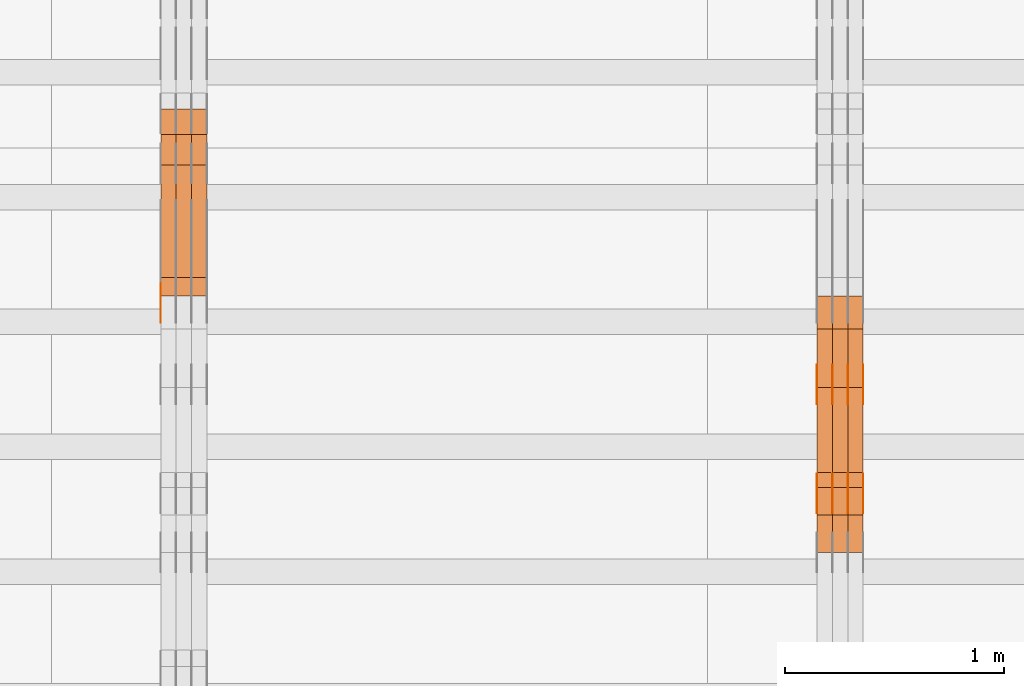
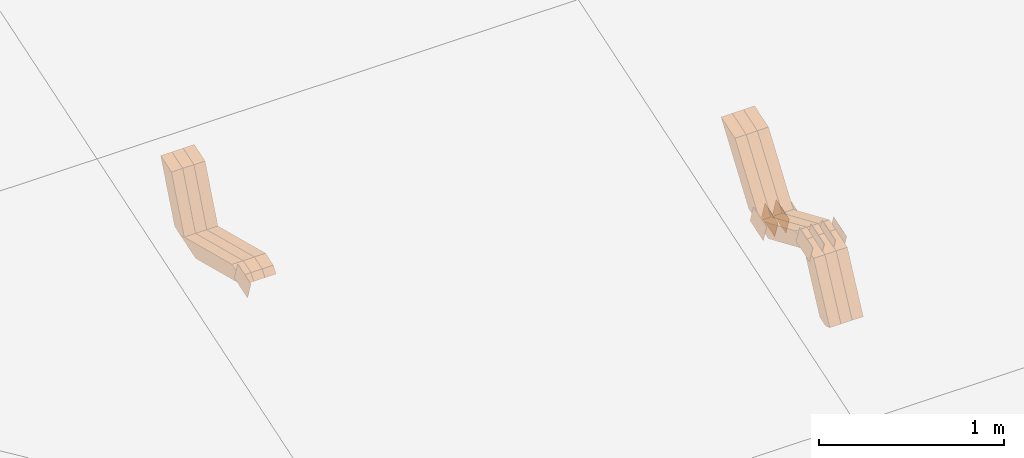
# One storey, part 133 of 385: 28 proxies.
"""IFC2X3 building model written with IfcOpenShell, lengths in millimetres."""

from ifc_helpers import new_model, entity, si_unit, converted_unit, derived_unit, direction, frame, origin, place, context, subcontext, project, spatial, polyline, outline, extrude, source, transform, mapped, material, type_object, type_shapes, element, save


model = new_model("IFC2X3")

# Units and contexts
model_context = context("Model", 3, precision=0.01, world=origin(), true_north=direction((6.12303176911189e-17, 1.0)))
body_context = subcontext(model_context, "Body", "Model", "MODEL_VIEW")
ifc_project = project(units=[si_unit("LENGTHUNIT", "METRE", prefix="MILLI"), si_unit("AREAUNIT", "SQUARE_METRE"), si_unit("VOLUMEUNIT", "CUBIC_METRE"), converted_unit("PLANEANGLEUNIT", "DEGREE", entity("IfcRatioMeasure", 0.0174532925199433), si_unit("PLANEANGLEUNIT", "RADIAN"), dimensions=[0, 0, 0, 0, 0, 0, 0]), si_unit("MASSUNIT", "GRAM", prefix="KILO"), derived_unit("MASSDENSITYUNIT", [(si_unit("MASSUNIT", "GRAM", prefix="KILO"), 1), (si_unit("LENGTHUNIT", "METRE"), -3)]), si_unit("TIMEUNIT", "SECOND"), si_unit("FREQUENCYUNIT", "HERTZ"), si_unit("THERMODYNAMICTEMPERATUREUNIT", "DEGREE_CELSIUS"), derived_unit("THERMALTRANSMITTANCEUNIT", [(si_unit("MASSUNIT", "GRAM", prefix="KILO"), 1), (si_unit("THERMODYNAMICTEMPERATUREUNIT", "KELVIN"), -1), (si_unit("TIMEUNIT", "SECOND"), -3)]), derived_unit("VOLUMETRICFLOWRATEUNIT", [(si_unit("LENGTHUNIT", "METRE"), 3), (si_unit("TIMEUNIT", "SECOND"), -1)]), si_unit("ELECTRICCURRENTUNIT", "AMPERE"), si_unit("ELECTRICVOLTAGEUNIT", "VOLT"), si_unit("POWERUNIT", "WATT"), si_unit("FORCEUNIT", "NEWTON", prefix="KILO"), si_unit("ILLUMINANCEUNIT", "LUX"), si_unit("LUMINOUSFLUXUNIT", "LUMEN"), si_unit("LUMINOUSINTENSITYUNIT", "CANDELA"), derived_unit("USERDEFINED", [(si_unit("MASSUNIT", "GRAM", prefix="KILO"), -1), (si_unit("LENGTHUNIT", "METRE"), -2), (si_unit("TIMEUNIT", "SECOND"), 3), (si_unit("LUMINOUSFLUXUNIT", "LUMEN"), 1)]), derived_unit("LINEARVELOCITYUNIT", [(si_unit("LENGTHUNIT", "METRE"), 1), (si_unit("TIMEUNIT", "SECOND"), -1)]), si_unit("PRESSUREUNIT", "PASCAL"), derived_unit("USERDEFINED", [(si_unit("LENGTHUNIT", "METRE"), -2), (si_unit("MASSUNIT", "GRAM", prefix="KILO"), 1), (si_unit("TIMEUNIT", "SECOND"), -2)])], contexts=[model_context])

# Site, building, storey
site_placement = place(None, origin())
site = spatial("IfcSite", under=ifc_project, at=site_placement, CompositionType="ELEMENT")
building_placement = place(site_placement, origin())
building = spatial("IfcBuilding", under=site, at=building_placement, CompositionType="ELEMENT")
storey_placement = place(building_placement, origin())
storey = spatial("IfcBuildingStorey", under=building, at=storey_placement, Name="Default", CompositionType="ELEMENT", Elevation=0.0)

# Proxies
ifc_material_1 = material(Name="IfcSurfaceStyle #345500")
building_element_proxy_type_1 = type_object("IfcBuildingElementProxyType", PredefinedType="NOTDEFINED", material=ifc_material_1)
shared_shape_1 = source(origin(), body_context, "Body", "SweptSolid", [
    extrude(outline(polyline([(-74.9998565677169, -60.0000596852269), (74.9998794200137, -60.0000596852269), (74.9998565677151, 60.0000596852269), (-74.9998794200119, 60.0000596852269), (-74.9998565677169, -60.0000596852269)])), frame((74.9998794200137, 60.0000596852269, 0.0), z_axis=(0.0, 0.0, 1.0), x_axis=(-1.0, 0.0, 0.0)), (0.0, 0.0, 1.0), 1.3),
])
type_shapes(building_element_proxy_type_1, [shared_shape_1])
proxy_1_placement = place(building_placement, frame((27386.3, 7527.6269081625, 1621.97418552253), z_axis=(-1.0, 0.0, 0.0), x_axis=(0.0, 0.951056516295124, 0.309016994375039)))
element("IfcBuildingElementProxy", 1, at=proxy_1_placement, inside=storey, type_object=building_element_proxy_type_1, material=ifc_material_1, context=body_context, shape_type="MappedRepresentation", body=[
    mapped(shared_shape_1, transform((0.0, 0.0, 0.0), scale=1.0)),
])
ifc_material_2 = material(Name="IfcSurfaceStyle #345443")
building_element_proxy_type_2 = type_object("IfcBuildingElementProxyType", PredefinedType="NOTDEFINED", material=ifc_material_2)
shared_shape_2 = source(origin(), body_context, "Body", "SweptSolid", [
    extrude(outline(polyline([(-74.9998565677169, -60.0000596852269), (74.9998794200137, -60.0000596852269), (74.9998565677151, 60.0000596852269), (-74.9998794200119, 60.0000596852269), (-74.9998565677169, -60.0000596852269)])), frame((74.9998794200137, 60.0000596852269, 0.0), z_axis=(0.0, 0.0, 1.0), x_axis=(-1.0, 0.0, 0.0)), (0.0, 0.0, 1.0), 1.3),
])
type_shapes(building_element_proxy_type_2, [shared_shape_2])
proxy_2_placement = place(building_placement, frame((27315.0, 7527.6269081625, 1621.97418552253), z_axis=(-1.0, 0.0, 0.0), x_axis=(0.0, 0.951056516295124, 0.309016994375039)))
element("IfcBuildingElementProxy", 2, at=proxy_2_placement, inside=storey, type_object=building_element_proxy_type_2, material=ifc_material_2, context=body_context, shape_type="MappedRepresentation", body=[
    mapped(shared_shape_2, transform((0.0, 0.0, 0.0), scale=1.0)),
])
ifc_material_3 = material(Name="IfcSurfaceStyle #345386")
building_element_proxy_type_3 = type_object("IfcBuildingElementProxyType", PredefinedType="NOTDEFINED", material=ifc_material_3)
shared_shape_3 = source(origin(), body_context, "Body", "SweptSolid", [
    extrude(outline(polyline([(-74.9998565677169, -60.0000596852269), (74.9998794200137, -60.0000596852269), (74.9998565677151, 60.0000596852269), (-74.9998794200119, 60.0000596852269), (-74.9998565677169, -60.0000596852269)])), frame((74.9998794200137, 60.0000596852269, 0.0), z_axis=(0.0, 0.0, 1.0), x_axis=(-1.0, 0.0, 0.0)), (0.0, 0.0, 1.0), 1.3),
])
type_shapes(building_element_proxy_type_3, [shared_shape_3])
proxy_3_placement = place(building_placement, frame((27316.3, 7527.6269081625, 1621.97418552253), z_axis=(-1.0, 0.0, 0.0), x_axis=(0.0, 0.951056516295124, 0.309016994375039)))
element("IfcBuildingElementProxy", 3, at=proxy_3_placement, inside=storey, type_object=building_element_proxy_type_3, material=ifc_material_3, context=body_context, shape_type="MappedRepresentation", body=[
    mapped(shared_shape_3, transform((0.0, 0.0, 0.0), scale=1.0)),
])
ifc_material_4 = material(Name="IfcSurfaceStyle #345329")
building_element_proxy_type_4 = type_object("IfcBuildingElementProxyType", PredefinedType="NOTDEFINED", material=ifc_material_4)
shared_shape_4 = source(origin(), body_context, "Body", "SweptSolid", [
    extrude(outline(polyline([(-74.9998565677169, -60.0000596852269), (74.9998794200137, -60.0000596852269), (74.9998565677151, 60.0000596852269), (-74.9998794200119, 60.0000596852269), (-74.9998565677169, -60.0000596852269)])), frame((74.9998794200137, 60.0000596852269, 0.0), z_axis=(0.0, 0.0, 1.0), x_axis=(-1.0, 0.0, 0.0)), (0.0, 0.0, 1.0), 1.29999999999999),
])
type_shapes(building_element_proxy_type_4, [shared_shape_4])
proxy_4_placement = place(building_placement, frame((27245.0, 7527.6269081625, 1621.97418552253), z_axis=(-1.0, 0.0, 0.0), x_axis=(0.0, 0.951056516295124, 0.309016994375039)))
element("IfcBuildingElementProxy", 4, at=proxy_4_placement, inside=storey, type_object=building_element_proxy_type_4, material=ifc_material_4, context=body_context, shape_type="MappedRepresentation", body=[
    mapped(shared_shape_4, transform((0.0, 0.0, 0.0), scale=1.0)),
])
ifc_material_5 = material(Name="IfcSurfaceStyle #345272")
building_element_proxy_type_5 = type_object("IfcBuildingElementProxyType", PredefinedType="NOTDEFINED", material=ifc_material_5)
shared_shape_5 = source(origin(), body_context, "Body", "SweptSolid", [
    extrude(outline(polyline([(-74.9998565677169, -60.0000596852269), (74.9998794200137, -60.0000596852269), (74.9998565677151, 60.0000596852269), (-74.9998794200119, 60.0000596852269), (-74.9998565677169, -60.0000596852269)])), frame((74.9998794200137, 60.0000596852269, 0.0), z_axis=(0.0, 0.0, 1.0), x_axis=(-1.0, 0.0, 0.0)), (0.0, 0.0, 1.0), 1.29999999999999),
])
type_shapes(building_element_proxy_type_5, [shared_shape_5])
proxy_5_placement = place(building_placement, frame((27246.3, 7527.6269081625, 1621.97418552253), z_axis=(-1.0, 0.0, 0.0), x_axis=(0.0, 0.951056516295124, 0.309016994375039)))
element("IfcBuildingElementProxy", 5, at=proxy_5_placement, inside=storey, type_object=building_element_proxy_type_5, material=ifc_material_5, context=body_context, shape_type="MappedRepresentation", body=[
    mapped(shared_shape_5, transform((0.0, 0.0, 0.0), scale=1.0)),
])
ifc_material_6 = material(Name="IfcSurfaceStyle #345215")
building_element_proxy_type_6 = type_object("IfcBuildingElementProxyType", PredefinedType="NOTDEFINED", material=ifc_material_6)
shared_shape_6 = source(origin(), body_context, "Body", "SweptSolid", [
    extrude(outline(polyline([(-74.9998565677169, -60.0000596852269), (74.9998794200137, -60.0000596852269), (74.9998565677151, 60.0000596852269), (-74.9998794200119, 60.0000596852269), (-74.9998565677169, -60.0000596852269)])), frame((74.9998794200137, 60.0000596852269, 0.0), z_axis=(0.0, 0.0, 1.0), x_axis=(-1.0, 0.0, 0.0)), (0.0, 0.0, 1.0), 1.29999999999999),
])
type_shapes(building_element_proxy_type_6, [shared_shape_6])
proxy_6_placement = place(building_placement, frame((27175.0, 7527.6269081625, 1621.97418552253), z_axis=(-1.0, 0.0, 0.0), x_axis=(0.0, 0.951056516295124, 0.309016994375039)))
element("IfcBuildingElementProxy", 6, at=proxy_6_placement, inside=storey, type_object=building_element_proxy_type_6, material=ifc_material_6, context=body_context, shape_type="MappedRepresentation", body=[
    mapped(shared_shape_6, transform((0.0, 0.0, 0.0), scale=1.0)),
])
ifc_material_7 = material(Name="IfcSurfaceStyle #335240")
building_element_proxy_type_7 = type_object("IfcBuildingElementProxyType", PredefinedType="NOTDEFINED", material=ifc_material_7)
shared_shape_7 = source(origin(), body_context, "Body", "SweptSolid", [
    extrude(outline(polyline([(-74.9998565677233, -60.0000596852342), (74.9998794200074, -60.0000596852342), (74.9998565677233, 60.0000596852342), (-74.9998794200074, 60.0000596852342), (-74.9998565677233, -60.0000596852342)])), frame((74.9998794200073, 60.0000596852342, 0.0), z_axis=(0.0, 0.0, 1.0), x_axis=(-1.0, 0.0, 0.0)), (0.0, 0.0, 1.0), 1.3),
])
type_shapes(building_element_proxy_type_7, [shared_shape_7])
proxy_7_placement = place(building_placement, frame((27386.3, 7029.15620503751, 1786.70025974129), z_axis=(-1.0, 0.0, 0.0), x_axis=(0.0, 0.951056516295154, 0.309016994374948)))
element("IfcBuildingElementProxy", 7, at=proxy_7_placement, inside=storey, type_object=building_element_proxy_type_7, material=ifc_material_7, context=body_context, shape_type="MappedRepresentation", body=[
    mapped(shared_shape_7, transform((0.0, 0.0, 0.0), scale=1.0)),
])
ifc_material_8 = material(Name="IfcSurfaceStyle #335183")
building_element_proxy_type_8 = type_object("IfcBuildingElementProxyType", PredefinedType="NOTDEFINED", material=ifc_material_8)
shared_shape_8 = source(origin(), body_context, "Body", "SweptSolid", [
    extrude(outline(polyline([(-74.9998565677233, -60.0000596852342), (74.9998794200074, -60.0000596852342), (74.9998565677233, 60.0000596852342), (-74.9998794200074, 60.0000596852342), (-74.9998565677233, -60.0000596852342)])), frame((74.9998794200073, 60.0000596852342, 0.0), z_axis=(0.0, 0.0, 1.0), x_axis=(-1.0, 0.0, 0.0)), (0.0, 0.0, 1.0), 1.3),
])
type_shapes(building_element_proxy_type_8, [shared_shape_8])
proxy_8_placement = place(building_placement, frame((27315.0, 7029.15620503751, 1786.70025974129), z_axis=(-1.0, 0.0, 0.0), x_axis=(0.0, 0.951056516295154, 0.309016994374948)))
element("IfcBuildingElementProxy", 8, at=proxy_8_placement, inside=storey, type_object=building_element_proxy_type_8, material=ifc_material_8, context=body_context, shape_type="MappedRepresentation", body=[
    mapped(shared_shape_8, transform((0.0, 0.0, 0.0), scale=1.0)),
])
ifc_material_9 = material(Name="IfcSurfaceStyle #335126")
building_element_proxy_type_9 = type_object("IfcBuildingElementProxyType", PredefinedType="NOTDEFINED", material=ifc_material_9)
shared_shape_9 = source(origin(), body_context, "Body", "SweptSolid", [
    extrude(outline(polyline([(-74.9998565677233, -60.0000596852342), (74.9998794200074, -60.0000596852342), (74.9998565677233, 60.0000596852342), (-74.9998794200074, 60.0000596852342), (-74.9998565677233, -60.0000596852342)])), frame((74.9998794200073, 60.0000596852342, 0.0), z_axis=(0.0, 0.0, 1.0), x_axis=(-1.0, 0.0, 0.0)), (0.0, 0.0, 1.0), 1.3),
])
type_shapes(building_element_proxy_type_9, [shared_shape_9])
proxy_9_placement = place(building_placement, frame((27316.3, 7029.15620503751, 1786.70025974129), z_axis=(-1.0, 0.0, 0.0), x_axis=(0.0, 0.951056516295154, 0.309016994374948)))
element("IfcBuildingElementProxy", 9, at=proxy_9_placement, inside=storey, type_object=building_element_proxy_type_9, material=ifc_material_9, context=body_context, shape_type="MappedRepresentation", body=[
    mapped(shared_shape_9, transform((0.0, 0.0, 0.0), scale=1.0)),
])
ifc_material_10 = material(Name="IfcSurfaceStyle #335069")
building_element_proxy_type_10 = type_object("IfcBuildingElementProxyType", PredefinedType="NOTDEFINED", material=ifc_material_10)
shared_shape_10 = source(origin(), body_context, "Body", "SweptSolid", [
    extrude(outline(polyline([(-74.9998565677233, -60.0000596852342), (74.9998794200074, -60.0000596852342), (74.9998565677233, 60.0000596852342), (-74.9998794200074, 60.0000596852342), (-74.9998565677233, -60.0000596852342)])), frame((74.9998794200073, 60.0000596852342, 0.0), z_axis=(0.0, 0.0, 1.0), x_axis=(-1.0, 0.0, 0.0)), (0.0, 0.0, 1.0), 1.29999999999999),
])
type_shapes(building_element_proxy_type_10, [shared_shape_10])
proxy_10_placement = place(building_placement, frame((27245.0, 7029.15620503751, 1786.70025974129), z_axis=(-1.0, 0.0, 0.0), x_axis=(0.0, 0.951056516295154, 0.309016994374948)))
element("IfcBuildingElementProxy", 10, at=proxy_10_placement, inside=storey, type_object=building_element_proxy_type_10, material=ifc_material_10, context=body_context, shape_type="MappedRepresentation", body=[
    mapped(shared_shape_10, transform((0.0, 0.0, 0.0), scale=1.0)),
])
ifc_material_11 = material(Name="IfcSurfaceStyle #335012")
building_element_proxy_type_11 = type_object("IfcBuildingElementProxyType", PredefinedType="NOTDEFINED", material=ifc_material_11)
shared_shape_11 = source(origin(), body_context, "Body", "SweptSolid", [
    extrude(outline(polyline([(-74.9998565677233, -60.0000596852342), (74.9998794200074, -60.0000596852342), (74.9998565677233, 60.0000596852342), (-74.9998794200074, 60.0000596852342), (-74.9998565677233, -60.0000596852342)])), frame((74.9998794200073, 60.0000596852342, 0.0), z_axis=(0.0, 0.0, 1.0), x_axis=(-1.0, 0.0, 0.0)), (0.0, 0.0, 1.0), 1.29999999999999),
])
type_shapes(building_element_proxy_type_11, [shared_shape_11])
proxy_11_placement = place(building_placement, frame((27246.3, 7029.15620503751, 1786.70025974129), z_axis=(-1.0, 0.0, 0.0), x_axis=(0.0, 0.951056516295154, 0.309016994374948)))
element("IfcBuildingElementProxy", 11, at=proxy_11_placement, inside=storey, type_object=building_element_proxy_type_11, material=ifc_material_11, context=body_context, shape_type="MappedRepresentation", body=[
    mapped(shared_shape_11, transform((0.0, 0.0, 0.0), scale=1.0)),
])
ifc_material_12 = material(Name="IfcSurfaceStyle #334955")
building_element_proxy_type_12 = type_object("IfcBuildingElementProxyType", PredefinedType="NOTDEFINED", material=ifc_material_12)
shared_shape_12 = source(origin(), body_context, "Body", "SweptSolid", [
    extrude(outline(polyline([(-74.9998565677233, -60.0000596852342), (74.9998794200074, -60.0000596852342), (74.9998565677233, 60.0000596852342), (-74.9998794200074, 60.0000596852342), (-74.9998565677233, -60.0000596852342)])), frame((74.9998794200073, 60.0000596852342, 0.0), z_axis=(0.0, 0.0, 1.0), x_axis=(-1.0, 0.0, 0.0)), (0.0, 0.0, 1.0), 1.29999999999999),
])
type_shapes(building_element_proxy_type_12, [shared_shape_12])
proxy_12_placement = place(building_placement, frame((27175.0, 7029.15620503751, 1786.70025974129), z_axis=(-1.0, 0.0, 0.0), x_axis=(0.0, 0.951056516295154, 0.309016994374948)))
element("IfcBuildingElementProxy", 12, at=proxy_12_placement, inside=storey, type_object=building_element_proxy_type_12, material=ifc_material_12, context=body_context, shape_type="MappedRepresentation", body=[
    mapped(shared_shape_12, transform((0.0, 0.0, 0.0), scale=1.0)),
])
ifc_material_13 = material(Name="IfcSurfaceStyle #322748")
building_element_proxy_type_13 = type_object("IfcBuildingElementProxyType", Name="T1-W17 322746", PredefinedType="NOTDEFINED", material=ifc_material_13)
shared_shape_13 = source(origin(), body_context, "Body", "SweptSolid", [
    extrude(outline(polyline([(-364.271754334175, -47.5002955168173), (154.762247185537, -47.5002955168173), (218.32500198375, 4.1746158945366e-05), (228.330650189718, 47.5002746437378), (-237.14614502483, 47.5002746437378), (-364.271754334175, -47.5002955168173)])), frame((228.330650189718, 47.5002746437378, 0.0), z_axis=(0.0, 0.0, 1.0), x_axis=(-1.0, 0.0, 0.0)), (0.0, 0.0, 1.0), 70.0),
])
type_shapes(building_element_proxy_type_13, [shared_shape_13])
proxy_13_placement = place(building_placement, frame((27385.0, 7603.591796875, 1617.27880859375), z_axis=(-1.0, 0.0, 0.0), x_axis=(0.0, 0.576852646364743, 0.816848226038346)))
element("IfcBuildingElementProxy", 13, at=proxy_13_placement, inside=storey, type_object=building_element_proxy_type_13, material=ifc_material_13, Name="T1-W17", context=body_context, shape_type="MappedRepresentation", body=[
    mapped(shared_shape_13, transform((0.0, 0.0, 0.0), scale=1.0)),
])
ifc_material_14 = material(Name="IfcSurfaceStyle #322682")
building_element_proxy_type_14 = type_object("IfcBuildingElementProxyType", Name="T1-W17 322680", PredefinedType="NOTDEFINED", material=ifc_material_14)
shared_shape_14 = source(origin(), body_context, "Body", "SweptSolid", [
    extrude(outline(polyline([(-364.271754334175, -47.5002955168173), (154.762247185537, -47.5002955168173), (218.32500198375, 4.1746158945366e-05), (228.330650189718, 47.5002746437378), (-237.14614502483, 47.5002746437378), (-364.271754334175, -47.5002955168173)])), frame((228.330650189718, 47.5002746437378, 0.0), z_axis=(0.0, 0.0, 1.0), x_axis=(-1.0, 0.0, 0.0)), (0.0, 0.0, 1.0), 70.0),
])
type_shapes(building_element_proxy_type_14, [shared_shape_14])
proxy_14_placement = place(building_placement, frame((27315.0, 7603.591796875, 1617.27880859375), z_axis=(-1.0, 0.0, 0.0), x_axis=(0.0, 0.576852646364743, 0.816848226038346)))
element("IfcBuildingElementProxy", 14, at=proxy_14_placement, inside=storey, type_object=building_element_proxy_type_14, material=ifc_material_14, Name="T1-W17", context=body_context, shape_type="MappedRepresentation", body=[
    mapped(shared_shape_14, transform((0.0, 0.0, 0.0), scale=1.0)),
])
ifc_material_15 = material(Name="IfcSurfaceStyle #322616")
building_element_proxy_type_15 = type_object("IfcBuildingElementProxyType", Name="T1-W17 322614", PredefinedType="NOTDEFINED", material=ifc_material_15)
shared_shape_15 = source(origin(), body_context, "Body", "SweptSolid", [
    extrude(outline(polyline([(-364.271754334175, -47.5002955168173), (154.762247185537, -47.5002955168173), (218.32500198375, 4.1746158945366e-05), (228.330650189718, 47.5002746437378), (-237.14614502483, 47.5002746437378), (-364.271754334175, -47.5002955168173)])), frame((228.330650189718, 47.5002746437378, 0.0), z_axis=(0.0, 0.0, 1.0), x_axis=(-1.0, 0.0, 0.0)), (0.0, 0.0, 1.0), 70.0),
])
type_shapes(building_element_proxy_type_15, [shared_shape_15])
proxy_15_placement = place(building_placement, frame((27245.0, 7603.591796875, 1617.27880859375), z_axis=(-1.0, 0.0, 0.0), x_axis=(0.0, 0.576852646364743, 0.816848226038346)))
element("IfcBuildingElementProxy", 15, at=proxy_15_placement, inside=storey, type_object=building_element_proxy_type_15, material=ifc_material_15, Name="T1-W17", context=body_context, shape_type="MappedRepresentation", body=[
    mapped(shared_shape_15, transform((0.0, 0.0, 0.0), scale=1.0)),
])
ifc_material_16 = material(Name="IfcSurfaceStyle #322352")
building_element_proxy_type_16 = type_object("IfcBuildingElementProxyType", Name="T1-W28 322350", PredefinedType="NOTDEFINED", material=ifc_material_16)
shared_shape_16 = source(origin(), body_context, "Body", "SweptSolid", [
    extrude(outline(polyline([(-217.926999432742, -47.5002417204892), (200.85556309928, -47.5002417204892), (198.503183549447, 8.27993157516647e-05), (144.500539771884, 47.5002003208314), (-325.932286987868, 47.5002003208314), (-217.926999432742, -47.5002417204892)])), frame((200.855855188284, 47.5002003208314, 0.0), z_axis=(0.0, 0.0, 1.0), x_axis=(-1.0, 0.0, 0.0)), (0.0, 0.0, 1.0), 70.0),
])
type_shapes(building_element_proxy_type_16, [shared_shape_16])
proxy_16_placement = place(building_placement, frame((27385.0, 7164.46308589723, 1806.71154838415), z_axis=(-1.0, 0.0, 0.0), x_axis=(0.0, 0.918207947119617, -0.396098681954861)))
element("IfcBuildingElementProxy", 16, at=proxy_16_placement, inside=storey, type_object=building_element_proxy_type_16, material=ifc_material_16, Name="T1-W28", context=body_context, shape_type="MappedRepresentation", body=[
    mapped(shared_shape_16, transform((0.0, 0.0, 0.0), scale=1.0)),
])
ifc_material_17 = material(Name="IfcSurfaceStyle #322286")
building_element_proxy_type_17 = type_object("IfcBuildingElementProxyType", Name="T1-W28 322284", PredefinedType="NOTDEFINED", material=ifc_material_17)
shared_shape_17 = source(origin(), body_context, "Body", "SweptSolid", [
    extrude(outline(polyline([(-217.926999432742, -47.5002417204892), (200.85556309928, -47.5002417204892), (198.503183549447, 8.27993157516647e-05), (144.500539771884, 47.5002003208314), (-325.932286987868, 47.5002003208314), (-217.926999432742, -47.5002417204892)])), frame((200.855855188284, 47.5002003208314, 0.0), z_axis=(0.0, 0.0, 1.0), x_axis=(-1.0, 0.0, 0.0)), (0.0, 0.0, 1.0), 70.0),
])
type_shapes(building_element_proxy_type_17, [shared_shape_17])
proxy_17_placement = place(building_placement, frame((27315.0, 7164.46308589723, 1806.71154838415), z_axis=(-1.0, 0.0, 0.0), x_axis=(0.0, 0.918207947119617, -0.396098681954861)))
element("IfcBuildingElementProxy", 17, at=proxy_17_placement, inside=storey, type_object=building_element_proxy_type_17, material=ifc_material_17, Name="T1-W28", context=body_context, shape_type="MappedRepresentation", body=[
    mapped(shared_shape_17, transform((0.0, 0.0, 0.0), scale=1.0)),
])
ifc_material_18 = material(Name="IfcSurfaceStyle #322220")
building_element_proxy_type_18 = type_object("IfcBuildingElementProxyType", Name="T1-W28 322218", PredefinedType="NOTDEFINED", material=ifc_material_18)
shared_shape_18 = source(origin(), body_context, "Body", "SweptSolid", [
    extrude(outline(polyline([(-217.926999432742, -47.5002417204892), (200.85556309928, -47.5002417204892), (198.503183549447, 8.27993157516647e-05), (144.500539771884, 47.5002003208314), (-325.932286987868, 47.5002003208314), (-217.926999432742, -47.5002417204892)])), frame((200.855855188284, 47.5002003208314, 0.0), z_axis=(0.0, 0.0, 1.0), x_axis=(-1.0, 0.0, 0.0)), (0.0, 0.0, 1.0), 70.0),
])
type_shapes(building_element_proxy_type_18, [shared_shape_18])
proxy_18_placement = place(building_placement, frame((27245.0, 7164.46308589723, 1806.71154838415), z_axis=(-1.0, 0.0, 0.0), x_axis=(0.0, 0.918207947119617, -0.396098681954861)))
element("IfcBuildingElementProxy", 18, at=proxy_18_placement, inside=storey, type_object=building_element_proxy_type_18, material=ifc_material_18, Name="T1-W28", context=body_context, shape_type="MappedRepresentation", body=[
    mapped(shared_shape_18, transform((0.0, 0.0, 0.0), scale=1.0)),
])
ifc_material_19 = material(Name="IfcSurfaceStyle #321956")
building_element_proxy_type_19 = type_object("IfcBuildingElementProxyType", Name="T1-W38 321954", PredefinedType="NOTDEFINED", material=ifc_material_19)
shared_shape_19 = source(origin(), body_context, "Body", "SweptSolid", [
    extrude(outline(polyline([(-298.027186733919, -47.5000251939178), (135.138415004037, -47.5000251939178), (181.282052802132, 0.000918984287993996), (187.347601017465, 47.4995657017738), (-205.740882089715, 47.4995657017739), (-298.027186733919, -47.5000251939178)])), frame((187.347846776827, 47.5001085012031, 0.0), z_axis=(0.0, 0.0, 1.0), x_axis=(-1.0, 0.0, 0.0)), (0.0, 0.0, 1.0), 70.0),
])
type_shapes(building_element_proxy_type_19, [shared_shape_19])
proxy_19_placement = place(building_placement, frame((27385.0, 6848.47987320449, 1368.44362234215), z_axis=(-1.0, 0.0, 0.0), x_axis=(0.0, 0.441034274474743, 0.897490261082836)))
element("IfcBuildingElementProxy", 19, at=proxy_19_placement, inside=storey, type_object=building_element_proxy_type_19, material=ifc_material_19, Name="T1-W38", context=body_context, shape_type="MappedRepresentation", body=[
    mapped(shared_shape_19, transform((0.0, 0.0, 0.0), scale=1.0)),
])
ifc_material_20 = material(Name="IfcSurfaceStyle #321890")
building_element_proxy_type_20 = type_object("IfcBuildingElementProxyType", Name="T1-W38 321888", PredefinedType="NOTDEFINED", material=ifc_material_20)
shared_shape_20 = source(origin(), body_context, "Body", "SweptSolid", [
    extrude(outline(polyline([(-298.027186733919, -47.5000251939178), (135.138415004037, -47.5000251939178), (181.282052802132, 0.000918984287993996), (187.347601017465, 47.4995657017738), (-205.740882089715, 47.4995657017739), (-298.027186733919, -47.5000251939178)])), frame((187.347846776827, 47.5001085012031, 0.0), z_axis=(0.0, 0.0, 1.0), x_axis=(-1.0, 0.0, 0.0)), (0.0, 0.0, 1.0), 70.0),
])
type_shapes(building_element_proxy_type_20, [shared_shape_20])
proxy_20_placement = place(building_placement, frame((27315.0, 6848.47987320449, 1368.44362234215), z_axis=(-1.0, 0.0, 0.0), x_axis=(0.0, 0.441034274474743, 0.897490261082836)))
element("IfcBuildingElementProxy", 20, at=proxy_20_placement, inside=storey, type_object=building_element_proxy_type_20, material=ifc_material_20, Name="T1-W38", context=body_context, shape_type="MappedRepresentation", body=[
    mapped(shared_shape_20, transform((0.0, 0.0, 0.0), scale=1.0)),
])
ifc_material_21 = material(Name="IfcSurfaceStyle #321824")
building_element_proxy_type_21 = type_object("IfcBuildingElementProxyType", Name="T1-W38 321822", PredefinedType="NOTDEFINED", material=ifc_material_21)
shared_shape_21 = source(origin(), body_context, "Body", "SweptSolid", [
    extrude(outline(polyline([(-298.027186733919, -47.5000251939178), (135.138415004037, -47.5000251939178), (181.282052802132, 0.000918984287993996), (187.347601017465, 47.4995657017738), (-205.740882089715, 47.4995657017739), (-298.027186733919, -47.5000251939178)])), frame((187.347846776827, 47.5001085012031, 0.0), z_axis=(0.0, 0.0, 1.0), x_axis=(-1.0, 0.0, 0.0)), (0.0, 0.0, 1.0), 70.0),
])
type_shapes(building_element_proxy_type_21, [shared_shape_21])
proxy_21_placement = place(building_placement, frame((27245.0, 6848.47987320449, 1368.44362234215), z_axis=(-1.0, 0.0, 0.0), x_axis=(0.0, 0.441034274474743, 0.897490261082836)))
element("IfcBuildingElementProxy", 21, at=proxy_21_placement, inside=storey, type_object=building_element_proxy_type_21, material=ifc_material_21, Name="T1-W38", context=body_context, shape_type="MappedRepresentation", body=[
    mapped(shared_shape_21, transform((0.0, 0.0, 0.0), scale=1.0)),
])
ifc_material_22 = material(Name="IfcSurfaceStyle #301207")
building_element_proxy_type_22 = type_object("IfcBuildingElementProxyType", PredefinedType="NOTDEFINED", material=ifc_material_22)
shared_shape_22 = source(origin(), body_context, "Body", "SweptSolid", [
    extrude(outline(polyline([(-74.9998754286253, -60.0000016373506), (74.9998605591091, -60.0000016373506), (74.9998754286234, 60.0000016373506), (-74.9998605591072, 60.0000016373506), (-74.9998754286253, -60.0000016373506)])), frame((75.0007355357002, 60.0002637031812, 0.0), z_axis=(0.0, 0.0, 1.0), x_axis=(-1.0, 0.0, 0.0)), (0.0, 0.0, 1.0), 1.29999999999999),
])
type_shapes(building_element_proxy_type_22, [shared_shape_22])
proxy_22_placement = place(building_placement, frame((24175.0, 7899.79204652808, 2069.58672486412), z_axis=(-1.0, 0.0, 0.0), x_axis=(0.0, 0.951056516295154, 0.309016994374948)))
element("IfcBuildingElementProxy", 22, at=proxy_22_placement, inside=storey, type_object=building_element_proxy_type_22, material=ifc_material_22, context=body_context, shape_type="MappedRepresentation", body=[
    mapped(shared_shape_22, transform((0.0, 0.0, 0.0), scale=1.0)),
])
ifc_material_23 = material(Name="IfcSurfaceStyle #289108")
building_element_proxy_type_23 = type_object("IfcBuildingElementProxyType", Name="T1-W45 289106", PredefinedType="NOTDEFINED", material=ifc_material_23)
shared_shape_23 = source(origin(), body_context, "Body", "SweptSolid", [
    extrude(outline(polyline([(-275.953018340717, -47.500197738425), (128.971267956636, -47.5001977384251), (168.669977842085, -0.000132525443043008), (174.867371111815, 47.5002640011466), (-196.55559856982, 47.5002640011466), (-275.953018340717, -47.500197738425)])), frame((174.867371111815, 47.5002640011466, 0.0), z_axis=(0.0, 0.0, 1.0), x_axis=(-1.0, 0.0, 0.0)), (0.0, 0.0, 1.0), 70.0),
])
type_shapes(building_element_proxy_type_23, [shared_shape_23])
proxy_23_placement = place(building_placement, frame((24385.0, 8621.494140625, 1941.33422851563), z_axis=(-1.0, 0.0, 0.0), x_axis=(0.0, 0.372787901688292, 0.927916580493549)))
element("IfcBuildingElementProxy", 23, at=proxy_23_placement, inside=storey, type_object=building_element_proxy_type_23, material=ifc_material_23, Name="T1-W45", context=body_context, shape_type="MappedRepresentation", body=[
    mapped(shared_shape_23, transform((0.0, 0.0, 0.0), scale=1.0)),
])
ifc_material_24 = material(Name="IfcSurfaceStyle #289042")
building_element_proxy_type_24 = type_object("IfcBuildingElementProxyType", Name="T1-W45 289040", PredefinedType="NOTDEFINED", material=ifc_material_24)
shared_shape_24 = source(origin(), body_context, "Body", "SweptSolid", [
    extrude(outline(polyline([(-275.953018340717, -47.500197738425), (128.971267956636, -47.5001977384251), (168.669977842085, -0.000132525443043008), (174.867371111815, 47.5002640011466), (-196.55559856982, 47.5002640011466), (-275.953018340717, -47.500197738425)])), frame((174.867371111815, 47.5002640011466, 0.0), z_axis=(0.0, 0.0, 1.0), x_axis=(-1.0, 0.0, 0.0)), (0.0, 0.0, 1.0), 70.0),
])
type_shapes(building_element_proxy_type_24, [shared_shape_24])
proxy_24_placement = place(building_placement, frame((24315.0, 8621.494140625, 1941.33422851563), z_axis=(-1.0, 0.0, 0.0), x_axis=(0.0, 0.372787901688292, 0.927916580493549)))
element("IfcBuildingElementProxy", 24, at=proxy_24_placement, inside=storey, type_object=building_element_proxy_type_24, material=ifc_material_24, Name="T1-W45", context=body_context, shape_type="MappedRepresentation", body=[
    mapped(shared_shape_24, transform((0.0, 0.0, 0.0), scale=1.0)),
])
ifc_material_25 = material(Name="IfcSurfaceStyle #288976")
building_element_proxy_type_25 = type_object("IfcBuildingElementProxyType", Name="T1-W45 288974", PredefinedType="NOTDEFINED", material=ifc_material_25)
shared_shape_25 = source(origin(), body_context, "Body", "SweptSolid", [
    extrude(outline(polyline([(-275.953018340717, -47.500197738425), (128.971267956636, -47.5001977384251), (168.669977842085, -0.000132525443043008), (174.867371111815, 47.5002640011466), (-196.55559856982, 47.5002640011466), (-275.953018340717, -47.500197738425)])), frame((174.867371111815, 47.5002640011466, 0.0), z_axis=(0.0, 0.0, 1.0), x_axis=(-1.0, 0.0, 0.0)), (0.0, 0.0, 1.0), 70.0),
])
type_shapes(building_element_proxy_type_25, [shared_shape_25])
proxy_25_placement = place(building_placement, frame((24245.0, 8621.494140625, 1941.33422851563), z_axis=(-1.0, 0.0, 0.0), x_axis=(0.0, 0.372787901688292, 0.927916580493549)))
element("IfcBuildingElementProxy", 25, at=proxy_25_placement, inside=storey, type_object=building_element_proxy_type_25, material=ifc_material_25, Name="T1-W45", context=body_context, shape_type="MappedRepresentation", body=[
    mapped(shared_shape_25, transform((0.0, 0.0, 0.0), scale=1.0)),
])
ifc_material_26 = material(Name="IfcSurfaceStyle #288712")
building_element_proxy_type_26 = type_object("IfcBuildingElementProxyType", Name="T1-W11 288710", PredefinedType="NOTDEFINED", material=ifc_material_26)
shared_shape_26 = source(origin(), body_context, "Body", "SweptSolid", [
    extrude(outline(polyline([(-261.366417792209, -47.5000378467523), (260.949520182121, -47.5000378467523), (242.928845159301, -7.41559889341215e-06), (168.237407166939, 47.5000415545517), (-410.749354716152, 47.5000415545517), (-261.366417792209, -47.5000378467523)])), frame((260.949520182121, 47.5000415545517, 0.0), z_axis=(0.0, 0.0, 1.0), x_axis=(-1.0, 0.0, 0.0)), (0.0, 0.0, 1.0), 70.0),
])
type_shapes(building_element_proxy_type_26, [shared_shape_26])
proxy_26_placement = place(building_placement, frame((24385.0, 8017.44318793234, 2097.03832883996), z_axis=(-1.0, 0.0, 0.0), x_axis=(0.0, 0.968347201599873, -0.249607085543851)))
element("IfcBuildingElementProxy", 26, at=proxy_26_placement, inside=storey, type_object=building_element_proxy_type_26, material=ifc_material_26, Name="T1-W11", context=body_context, shape_type="MappedRepresentation", body=[
    mapped(shared_shape_26, transform((0.0, 0.0, 0.0), scale=1.0)),
])
ifc_material_27 = material(Name="IfcSurfaceStyle #288646")
building_element_proxy_type_27 = type_object("IfcBuildingElementProxyType", Name="T1-W11 288644", PredefinedType="NOTDEFINED", material=ifc_material_27)
shared_shape_27 = source(origin(), body_context, "Body", "SweptSolid", [
    extrude(outline(polyline([(-261.366417792209, -47.5000378467523), (260.949520182121, -47.5000378467523), (242.928845159301, -7.41559889341215e-06), (168.237407166939, 47.5000415545517), (-410.749354716152, 47.5000415545517), (-261.366417792209, -47.5000378467523)])), frame((260.949520182121, 47.5000415545517, 0.0), z_axis=(0.0, 0.0, 1.0), x_axis=(-1.0, 0.0, 0.0)), (0.0, 0.0, 1.0), 70.0),
])
type_shapes(building_element_proxy_type_27, [shared_shape_27])
proxy_27_placement = place(building_placement, frame((24315.0, 8017.44318793234, 2097.03832883996), z_axis=(-1.0, 0.0, 0.0), x_axis=(0.0, 0.968347201599873, -0.249607085543851)))
element("IfcBuildingElementProxy", 27, at=proxy_27_placement, inside=storey, type_object=building_element_proxy_type_27, material=ifc_material_27, Name="T1-W11", context=body_context, shape_type="MappedRepresentation", body=[
    mapped(shared_shape_27, transform((0.0, 0.0, 0.0), scale=1.0)),
])
ifc_material_28 = material(Name="IfcSurfaceStyle #288580")
building_element_proxy_type_28 = type_object("IfcBuildingElementProxyType", Name="T1-W11 288578", PredefinedType="NOTDEFINED", material=ifc_material_28)
shared_shape_28 = source(origin(), body_context, "Body", "SweptSolid", [
    extrude(outline(polyline([(-261.366417792209, -47.5000378467523), (260.949520182121, -47.5000378467523), (242.928845159301, -7.41559889341215e-06), (168.237407166939, 47.5000415545517), (-410.749354716152, 47.5000415545517), (-261.366417792209, -47.5000378467523)])), frame((260.949520182121, 47.5000415545517, 0.0), z_axis=(0.0, 0.0, 1.0), x_axis=(-1.0, 0.0, 0.0)), (0.0, 0.0, 1.0), 70.0),
])
type_shapes(building_element_proxy_type_28, [shared_shape_28])
proxy_28_placement = place(building_placement, frame((24245.0, 8017.44318793234, 2097.03832883996), z_axis=(-1.0, 0.0, 0.0), x_axis=(0.0, 0.968347201599873, -0.249607085543851)))
element("IfcBuildingElementProxy", 28, at=proxy_28_placement, inside=storey, type_object=building_element_proxy_type_28, material=ifc_material_28, Name="T1-W11", context=body_context, shape_type="MappedRepresentation", body=[
    mapped(shared_shape_28, transform((0.0, 0.0, 0.0), scale=1.0)),
])

save(model, "model.ifc")
